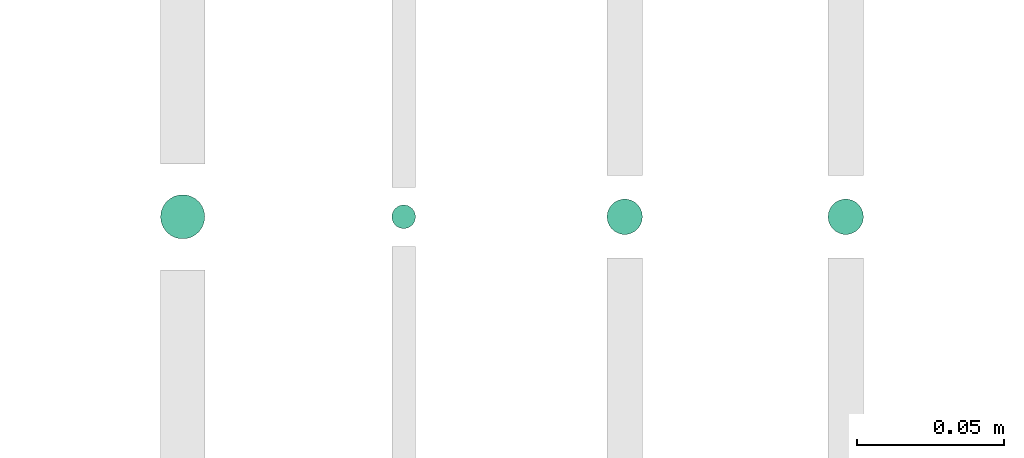
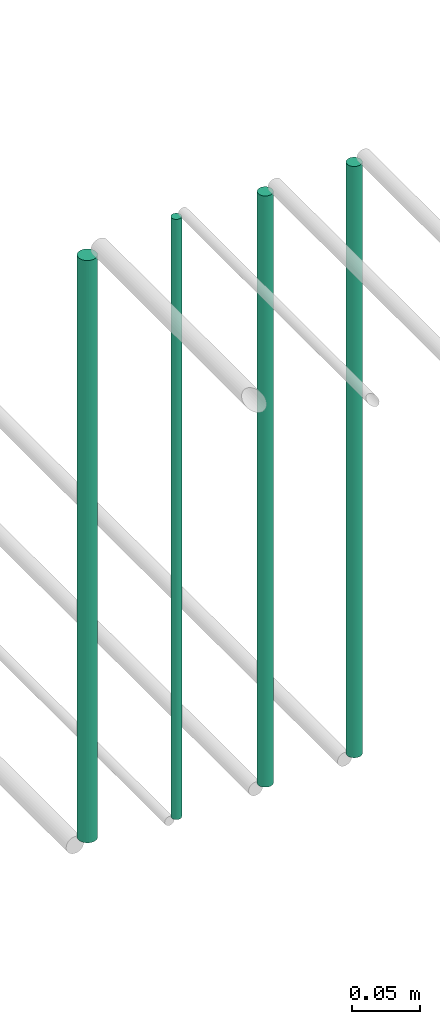
# One storey, part 40 of 65: 4 flow segments.
"""IFC2X3 building model written with IfcOpenShell, lengths in millimetres."""

from ifc_helpers import new_model, entity, si_unit, converted_unit, derived_unit, direction, frame, origin, origin_2d_with_axis, place, context, subcontext, project, spatial, circle, extrude, type_object, element, save


model = new_model("IFC2X3")

# Units and contexts
model_context = context("Model", 3, precision=0.01, world=origin(), true_north=direction((6.12303176911189e-17, 1.0)))
body_context = subcontext(model_context, "Body", "Model", "MODEL_VIEW")
ifc_project = project(units=[si_unit("LENGTHUNIT", "METRE", prefix="MILLI"), si_unit("AREAUNIT", "SQUARE_METRE"), si_unit("VOLUMEUNIT", "CUBIC_METRE"), converted_unit("PLANEANGLEUNIT", "DEGREE", entity("IfcRatioMeasure", 0.0174532925199433), si_unit("PLANEANGLEUNIT", "RADIAN"), dimensions=[0, 0, 0, 0, 0, 0, 0]), si_unit("MASSUNIT", "GRAM", prefix="KILO"), derived_unit("MASSDENSITYUNIT", [(si_unit("MASSUNIT", "GRAM", prefix="KILO"), 1), (si_unit("LENGTHUNIT", "METRE"), -3)]), derived_unit("MOMENTOFINERTIAUNIT", [(si_unit("LENGTHUNIT", "METRE"), 4)]), si_unit("TIMEUNIT", "SECOND"), si_unit("FREQUENCYUNIT", "HERTZ"), si_unit("THERMODYNAMICTEMPERATUREUNIT", "DEGREE_CELSIUS"), derived_unit("THERMALTRANSMITTANCEUNIT", [(si_unit("MASSUNIT", "GRAM", prefix="KILO"), 1), (si_unit("THERMODYNAMICTEMPERATUREUNIT", "KELVIN"), -1), (si_unit("TIMEUNIT", "SECOND"), -3)]), derived_unit("VOLUMETRICFLOWRATEUNIT", [(si_unit("LENGTHUNIT", "METRE"), 3), (si_unit("TIMEUNIT", "SECOND"), -1)]), derived_unit("MASSFLOWRATEUNIT", [(si_unit("MASSUNIT", "GRAM", prefix="KILO"), 1), (si_unit("TIMEUNIT", "SECOND"), -1)]), derived_unit("ROTATIONALFREQUENCYUNIT", [(si_unit("TIMEUNIT", "SECOND"), -1)]), si_unit("ELECTRICCURRENTUNIT", "AMPERE"), si_unit("ELECTRICVOLTAGEUNIT", "VOLT"), si_unit("POWERUNIT", "WATT"), si_unit("FORCEUNIT", "NEWTON", prefix="KILO"), si_unit("ILLUMINANCEUNIT", "LUX"), si_unit("LUMINOUSFLUXUNIT", "LUMEN"), si_unit("LUMINOUSINTENSITYUNIT", "CANDELA"), derived_unit("USERDEFINED", [(si_unit("MASSUNIT", "GRAM", prefix="KILO"), -1), (si_unit("LENGTHUNIT", "METRE"), -2), (si_unit("TIMEUNIT", "SECOND"), 3), (si_unit("LUMINOUSFLUXUNIT", "LUMEN"), 1)]), derived_unit("LINEARVELOCITYUNIT", [(si_unit("LENGTHUNIT", "METRE"), 1), (si_unit("TIMEUNIT", "SECOND"), -1)]), si_unit("PRESSUREUNIT", "PASCAL"), derived_unit("USERDEFINED", [(si_unit("LENGTHUNIT", "METRE"), -2), (si_unit("MASSUNIT", "GRAM", prefix="KILO"), 1), (si_unit("TIMEUNIT", "SECOND"), -2)]), derived_unit("LINEARFORCEUNIT", [(si_unit("MASSUNIT", "GRAM", prefix="KILO"), 1), (si_unit("LENGTHUNIT", "METRE"), 1), (si_unit("TIMEUNIT", "SECOND"), -2), (si_unit("LENGTHUNIT", "METRE"), -1)]), derived_unit("PLANARFORCEUNIT", [(si_unit("MASSUNIT", "GRAM", prefix="KILO"), 1), (si_unit("LENGTHUNIT", "METRE"), 1), (si_unit("TIMEUNIT", "SECOND"), -2), (si_unit("LENGTHUNIT", "METRE"), -2)])], contexts=[model_context])

# Site, building, storey
site_placement = place(None, frame((0.0, -0.00077364408347762, 0.0)))
site = spatial("IfcSite", under=ifc_project, at=site_placement, CompositionType="ELEMENT")
building_placement = place(site_placement, origin())
building = spatial("IfcBuilding", under=site, at=building_placement, CompositionType="ELEMENT")
storey_placement = place(building_placement, frame((0.0, 0.0, 19800.0)))
storey = spatial("IfcBuildingStorey", under=building, at=storey_placement, CompositionType="ELEMENT", Elevation=19800.0)

# Flow segments
pipe_segment_type = type_object("IfcPipeSegmentType", PredefinedType="NOTDEFINED")
flow_segment_1_placement = place(storey_placement, frame((59896.8052438068, 4690.90472776408, 2643.0)))
element("IfcFlowSegment", 1, at=flow_segment_1_placement, inside=storey, type_object=pipe_segment_type, context=body_context, shape_type="SweptSolid", body=[
    extrude(circle(Radius=7.5, at=origin_2d_with_axis()), frame((9.09527223591419, 9.09527223591582, 0.0), z_axis=(0.0, 0.0, 1.0), x_axis=(-1.0, 0.0, 0.0)), (0.0, 0.0, 1.0), 518.999999999817),
])
flow_segment_2_placement = place(storey_placement, frame((59975.3052438068, 4694.40472776407, 2635.0)))
element("IfcFlowSegment", 2, at=flow_segment_2_placement, inside=storey, type_object=pipe_segment_type, context=body_context, shape_type="SweptSolid", body=[
    extrude(circle(Radius=4.0, at=origin_2d_with_axis()), frame((5.59527223591499, 5.59527223591607, 0.0), z_axis=(0.0, 0.0, 1.0), x_axis=(-1.0, 0.0, 0.0)), (0.0, 0.0, 1.0), 535.000000000099),
])
flow_segment_3_placement = place(storey_placement, frame((60048.3052438068, 4692.40472776409, 2639.0)))
element("IfcFlowSegment", 3, at=flow_segment_3_placement, inside=storey, type_object=pipe_segment_type, context=body_context, shape_type="SweptSolid", body=[
    extrude(circle(Radius=6.0, at=origin_2d_with_axis()), frame((7.59527223591454, 7.59527223591616, 0.0)), (0.0, 0.0, 1.0), 527.000000000162),
])
flow_segment_4_placement = place(storey_placement, frame((60123.3052438068, 4692.40472776407, 2639.0)))
element("IfcFlowSegment", 4, at=flow_segment_4_placement, inside=storey, type_object=pipe_segment_type, context=body_context, shape_type="SweptSolid", body=[
    extrude(circle(Radius=6.0, at=origin_2d_with_axis()), frame((7.59527223591454, 7.59527223591616, 0.0), z_axis=(0.0, 0.0, 1.0), x_axis=(-1.0, 0.0, 0.0)), (0.0, 0.0, 1.0), 527.000000000058),
])

save(model, "model.ifc")
